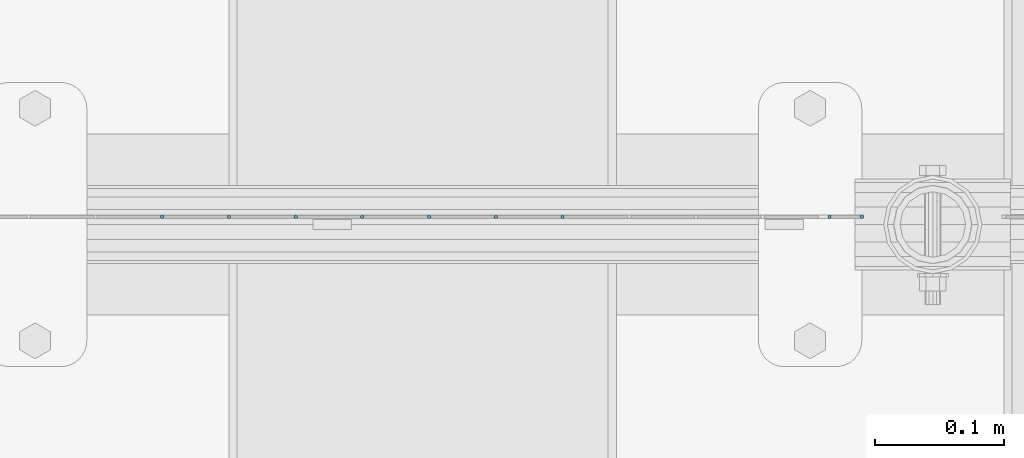
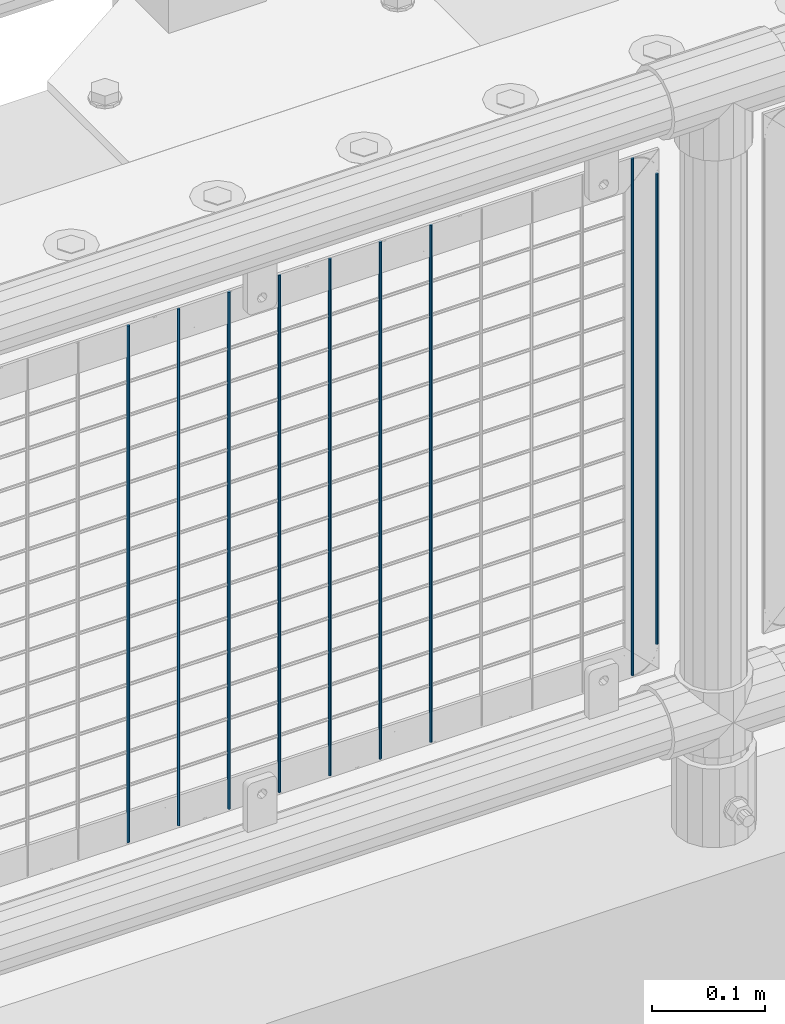
# One storey, part 78 of 240: 9 columns.
"""IFC2X3 building model written with IfcOpenShell, lengths in millimetres."""

from ifc_helpers import new_model, si_unit, frame, origin_with_axes, place, context, subcontext, project, spatial, faceted_brep, material, type_object, element, save


model = new_model("IFC2X3")

# Units and contexts
model_context = context("Model", 3, precision=1e-05, world=origin_with_axes())
body_context = subcontext(model_context, "Body", "Model", "MODEL_VIEW")
ifc_project = project(units=[si_unit("LENGTHUNIT", "METRE", prefix="MILLI"), si_unit("AREAUNIT", "SQUARE_METRE"), si_unit("VOLUMEUNIT", "CUBIC_METRE"), si_unit("MASSUNIT", "GRAM", prefix="KILO"), si_unit("TIMEUNIT", "SECOND"), si_unit("PLANEANGLEUNIT", "RADIAN"), si_unit("SOLIDANGLEUNIT", "STERADIAN"), si_unit("THERMODYNAMICTEMPERATUREUNIT", "DEGREE_CELSIUS"), si_unit("LUMINOUSINTENSITYUNIT", "LUMEN")], contexts=[model_context])

# Site, building, storey
site_placement = place(None, origin_with_axes())
site = spatial("IfcSite", under=ifc_project, at=site_placement, CompositionType="ELEMENT")
building_placement = place(site_placement, origin_with_axes())
building = spatial("IfcBuilding", under=site, at=building_placement, Name="Standard", CompositionType="ELEMENT")
storey_placement = place(building_placement, origin_with_axes())
storey = spatial("IfcBuildingStorey", under=building, at=storey_placement, Name="Undefined", CompositionType="ELEMENT", Elevation=0.0)

# Columns
ifc_material = material(Name="Misc_Undefined")
column_type = type_object("IfcColumnType", Name="D3", PredefinedType="NOTDEFINED")
for number, where, z_axis, x_axis in (
    (1, (47758.375, 34670.5, 353.02), (-1.0, 0.0, 0.0), (0.0, 0.0, 1.0)),
    (2, (47706.72, 34670.5, 353.02), (-1.0, 0.0, 0.0), (0.0, 0.0, 1.0)),
    (3, (47655.065, 34670.5, 353.02), (-1.0, 0.0, 0.0), (0.0, 0.0, 1.0)),
    (4, (47603.41, 34670.5, 353.02), (-1.0, 0.0, 0.0), (0.0, 0.0, 1.0)),
    (5, (47551.755, 34670.5, 353.02), (-1.0, 0.0, 0.0), (0.0, 0.0, 1.0)),
    (6, (47500.1, 34670.5, 353.02), (-1.0, 0.0, 0.0), (0.0, 0.0, 1.0)),
    (7, (47448.445, 34670.5, 353.02), (-1.0, 0.0, 0.0), (0.0, 0.0, 1.0)),
    (8, (47964.995, 34670.5, 353.02), (-1.0, 0.0, 0.0), (0.0, 0.0, 1.0)),
):
    element("IfcColumn", number, at=place(storey_placement, frame(where, z_axis=z_axis, x_axis=x_axis)), inside=storey, type_object=column_type, material=ifc_material, ObjectType="D3", context=body_context, shape_type="Brep", body=[
        faceted_brep([(-7.27595761418343e-12, -1.49999999999272, 0.0), (-7.27595761418343e-12, -0.749999999992724, -1.29903810567669), (560.0, -0.75, -1.29903810567339), (560.0, -1.5, 0.0), (0.0, 0.750000000007276, -1.29903810567669), (560.0, 0.75, -1.29903810567339), (0.0, 1.50000000000728, 0.0), (560.0, 1.5, 0.0), (0.0, 0.750000000007276, 1.29903810567669), (560.0, 0.75, 1.29903810567339), (-7.27595761418343e-12, -0.749999999992724, 1.29903810567669), (560.0, -0.75, 1.29903810567339)], [[[0, 1, 2, 3]], [[1, 4, 5, 2]], [[4, 6, 7, 5]], [[6, 8, 9, 7]], [[8, 10, 11, 9]], [[10, 0, 3, 11]], [[5, 7, 9, 11, 3, 2]], [[10, 8, 6, 4, 1, 0]]]),
    ])
column_placement = place(storey_placement, frame((47990.0, 34670.5, 378.02), z_axis=(-1.0, 0.0, 0.0), x_axis=(0.0, 0.0, 1.0)))
element("IfcColumn", 9, at=column_placement, inside=storey, type_object=column_type, material=ifc_material, ObjectType="D3", context=body_context, shape_type="Brep", body=[
    faceted_brep([(-7.27595761418343e-12, -1.49999999999272, 0.0), (-7.27595761418343e-12, -0.749999999992724, -1.29903810567669), (510.0, -0.75, -1.29903810567339), (510.0, -1.5, 0.0), (0.0, 0.750000000007276, -1.29903810567669), (510.0, 0.75, -1.29903810567339), (0.0, 1.50000000000728, 0.0), (510.0, 1.5, 0.0), (0.0, 0.750000000007276, 1.29903810567669), (510.0, 0.75, 1.29903810567339), (-7.27595761418343e-12, -0.749999999992724, 1.29903810567669), (510.0, -0.75, 1.29903810567339)], [[[0, 1, 2, 3]], [[1, 4, 5, 2]], [[4, 6, 7, 5]], [[6, 8, 9, 7]], [[8, 10, 11, 9]], [[10, 0, 3, 11]], [[5, 7, 9, 11, 3, 2]], [[10, 8, 6, 4, 1, 0]]]),
])

save(model, "model.ifc")
